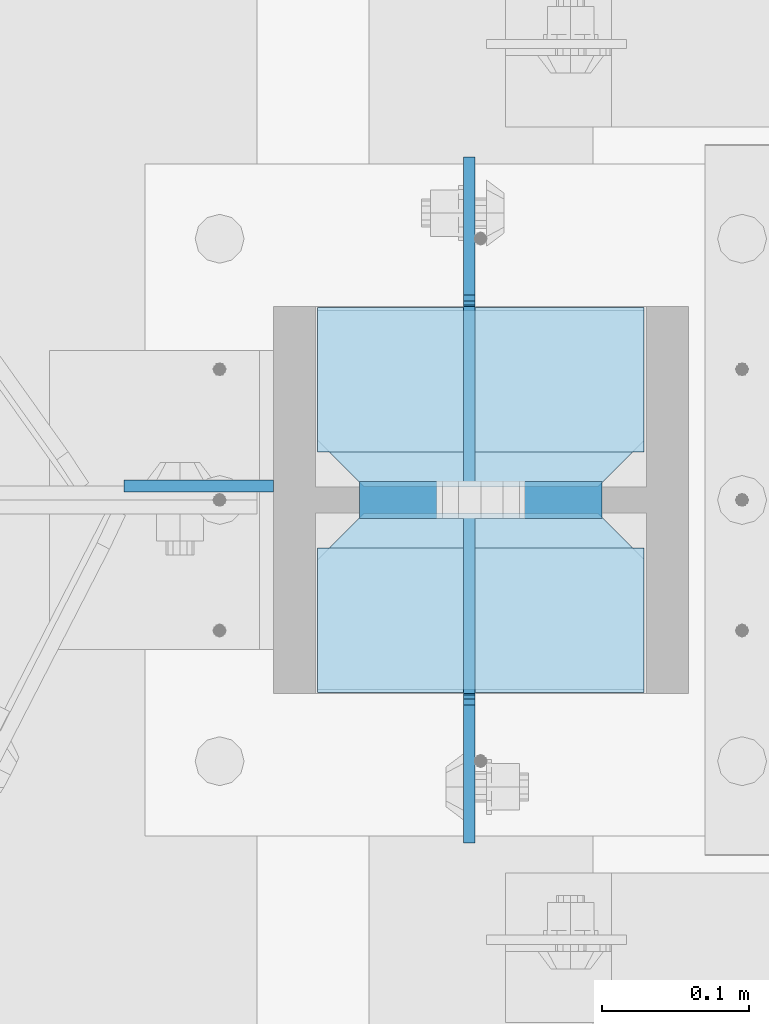
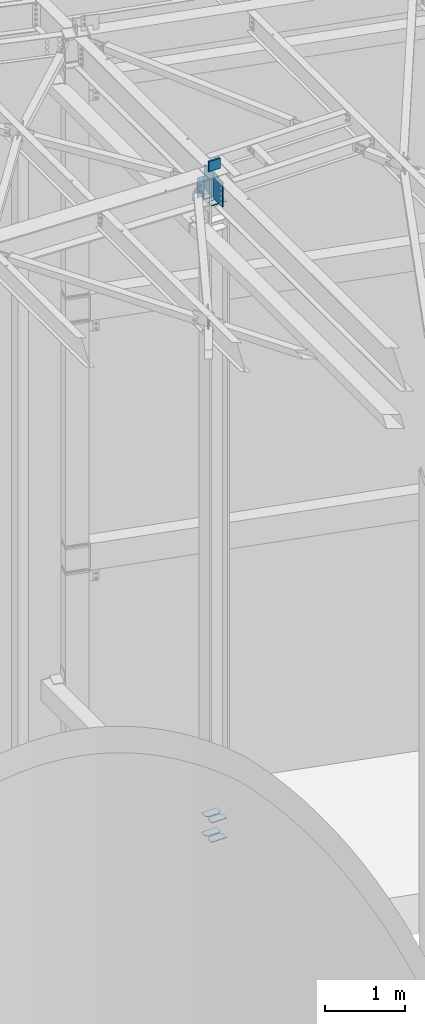
# One storey, part 1661 of 1763: 10 plates, 1 element without a shape of its own.
"""IFC2X3 building model written with IfcOpenShell, lengths in millimetres."""

import ifcopenshell
import ifcopenshell.guid

model = None  # the IFC model being written
_history = None  # IfcOwnerHistory: only IFC2X3 demands one
_inside = {}  # id of a spatial element -> (the spatial element, [elements in it])
_under = {}  # id of a project, library or spatial element -> (it, [spatial elements below it])
_declared = {}  # id of a project -> (the project, [libraries it declares])
_typed = {}  # id of a type object -> (the type object, [elements of that type])
_made_of = {}  # id of a material, layer set ... -> (it, [elements and type objects made of it])


def new_model(schema):
    """Start an empty IFC model of exactly this schema.

    Asked for "IFC4X3", IfcOpenShell would pick the latest addendum, in which some entities
    have other attributes; the version numbers below select the first issue.
    IFC2X3 requires an IfcOwnerHistory on every rooted entity: one is made here for all.
    """
    global model, _history
    if schema == "IFC4X3":
        model = ifcopenshell.file(schema_version=(4, 3, 0, 0))
    else:
        model = ifcopenshell.file(schema=schema)
    _inside.clear()
    _under.clear()
    _declared.clear()
    _typed.clear()
    _made_of.clear()
    _history = None
    if model.schema == "IFC2X3":
        org = make("IfcOrganization", Name="unknown")
        user = make(
            "IfcPersonAndOrganization",
            ThePerson=make("IfcPerson", FamilyName="unknown"),
            TheOrganization=org,
        )
        app = make(
            "IfcApplication",
            ApplicationDeveloper=org,
            Version="unknown",
            ApplicationFullName="unknown",
            ApplicationIdentifier="unknown",
        )
        _history = make(
            "IfcOwnerHistory",
            OwningUser=user,
            OwningApplication=app,
            ChangeAction="ADDED",
            CreationDate=0,
        )
    return model


def make(cls, **values):
    """One entity of the class cls with the attributes given. An attribute that is None is left unset."""
    return model.create_entity(
        cls, **{name: value for name, value in values.items() if value is not None}
    )


def rooted(cls, **values):
    """An entity with a GlobalId (a new one), such as an element, a storey or a relation."""
    return make(cls, GlobalId=ifcopenshell.guid.new(), OwnerHistory=_history, **values)


def si_unit(unit_type, name, prefix=None):
    """IfcSIUnit, for example si_unit("LENGTHUNIT", "METRE", prefix="MILLI")."""
    return make("IfcSIUnit", UnitType=unit_type, Prefix=prefix, Name=name)


def assignment(units):
    """IfcUnitAssignment: the units of a project."""
    return None if units is None else make("IfcUnitAssignment", Units=units)


def point(xyz):
    """IfcCartesianPoint."""
    return None if xyz is None else make("IfcCartesianPoint", Coordinates=xyz)


def direction(xyz):
    """IfcDirection."""
    return None if xyz is None else make("IfcDirection", DirectionRatios=xyz)


def frame(location, z_axis=None, x_axis=None):
    """IfcAxis2Placement3D, a coordinate frame: its origin and axes. An axis left out is left unset."""
    return make(
        "IfcAxis2Placement3D",
        Location=point(location),
        Axis=direction(z_axis),
        RefDirection=direction(x_axis),
    )


def origin_with_axes():
    """The frame at (0, 0, 0) with the z axis (0, 0, 1) and the x axis (1, 0, 0) written out."""
    return frame((0.0, 0.0, 0.0), z_axis=(0.0, 0.0, 1.0), x_axis=(1.0, 0.0, 0.0))


def place(relative_to, where):
    """IfcLocalPlacement: puts the frame where relative to a parent placement (None: the world)."""
    return make(
        "IfcLocalPlacement", PlacementRelTo=relative_to, RelativePlacement=where
    )


def context(
    kind, dimensions, precision=None, world=None, true_north=None, identifier=None
):
    """IfcGeometricRepresentationContext, for example the 3D "Model" context."""
    return make(
        "IfcGeometricRepresentationContext",
        ContextIdentifier=identifier,
        ContextType=kind,
        CoordinateSpaceDimension=dimensions,
        Precision=precision,
        WorldCoordinateSystem=world,
        TrueNorth=true_north,
    )


def subcontext(parent, identifier, kind, view, scale=None):
    """IfcGeometricRepresentationSubContext, for example "Body" below "Model"."""
    return make(
        "IfcGeometricRepresentationSubContext",
        ContextIdentifier=identifier,
        ContextType=kind,
        ParentContext=parent,
        TargetScale=scale,
        TargetView=view,
    )


def project(units=None, contexts=None):
    """IfcProject with its units and contexts."""
    return rooted(
        "IfcProject",
        Name="project",
        RepresentationContexts=contexts,
        UnitsInContext=assignment(units),
    )


def spatial(cls, under=None, at=None, **own):
    """A site, building, storey or space (cls), placed at a placement, below another one or the project."""
    s = rooted(cls, ObjectPlacement=at, **own)
    if under is not None:
        _under.setdefault(under.id(), (under, []))[1].append(s)
    return s


def faces_of(points, faces, orient=None, outer=None):
    """IfcFace entities. A face is a list of loops; a loop is a list of indices into points, from 0.

    orient and outer hold one flag for each loop. By default every Orientation is true, the
    first loop of a face is its IfcFaceOuterBound and the others are IfcFaceBound.
    """
    made = []
    for i, loops in enumerate(faces):
        bounds = []
        for j, loop in enumerate(loops):
            is_outer = j == 0 if outer is None else outer[i][j]
            bounds.append(
                make(
                    "IfcFaceOuterBound" if is_outer else "IfcFaceBound",
                    Bound=make("IfcPolyLoop", Polygon=[points[k] for k in loop]),
                    Orientation=True if orient is None else orient[i][j],
                )
            )
        made.append(make("IfcFace", Bounds=bounds))
    return made


def faceted_brep(points, faces, orient=None, outer=None, voids=None):
    """IfcFacetedBrep: a solid bounded by flat faces; with voids (closed shells), ...WithVoids."""
    shared = [point(p) for p in points]
    hull = make("IfcClosedShell", CfsFaces=faces_of(shared, faces, orient, outer))
    if voids is None:
        return make("IfcFacetedBrep", Outer=hull)
    return make(
        "IfcFacetedBrepWithVoids",
        Outer=hull,
        Voids=[
            make(cls, CfsFaces=faces_of(shared, fs, o, b)) for cls, fs, o, b in voids
        ],
    )


def shape(context_of_items, identifier, shape_type, items):
    """IfcShapeRepresentation: the items that make up one representation, for example the "Body"."""
    return make(
        "IfcShapeRepresentation",
        ContextOfItems=context_of_items,
        RepresentationIdentifier=identifier,
        RepresentationType=shape_type,
        Items=items,
    )


def material(Name=None, Category=None):
    """IfcMaterial."""
    return make("IfcMaterial", Name=Name, Category=Category)


def made_of(thing, what):
    """Note that an element or type object is made of a material, layer set ...; save() writes the relation."""
    if what is not None:
        _made_of.setdefault(what.id(), (what, []))[1].append(thing)
    return thing


def type_object(cls, material=None, **own):
    """A type object (cls), such as IfcWallType, which elements share."""
    return made_of(rooted(cls, **own), material)


def element(
    cls,
    number,
    at=None,
    inside=None,
    cuts=None,
    type_object=None,
    material=None,
    context=None,
    identifier="Body",
    shape_type=None,
    held_by="IfcProductDefinitionShape",
    body=None,
    shapes=None,
    **own,
):
    """One element of the class cls, such as IfcWall. Its Tag is "e" and its number.

    at: its placement. inside: the storey or other place that contains it. cuts: it is an
    opening in that element (IfcRelVoidsElement). A single representation is given by context,
    identifier, shape_type and body (its items); several are given by shapes. held_by: the class
    of the entity that holds the representations. save() writes the other relations.
    """
    e = rooted(cls, Tag="e%d" % number, ObjectPlacement=at, **own)
    if body is not None:
        shapes = [shape(context, identifier, shape_type, body)]
    if shapes is not None:
        e.Representation = make(held_by, Representations=shapes)
    if inside is not None:
        _inside.setdefault(inside.id(), (inside, []))[1].append(e)
    if cuts is not None:
        rooted(
            "IfcRelVoidsElement", RelatingBuildingElement=cuts, RelatedOpeningElement=e
        )
    if type_object is not None:
        _typed.setdefault(type_object.id(), (type_object, []))[1].append(e)
    return made_of(e, material)


def aggregate(whole, parts):
    """IfcRelAggregates: a whole, such as a stair, and the parts it consists of."""
    return rooted("IfcRelAggregates", RelatingObject=whole, RelatedObjects=parts)


def save(model, path):
    """Write the relations noted so far, then the file.

    IfcRelAggregates (storeys below a building ...), IfcRelContainedInSpatialStructure (elements
    in a storey), IfcRelDefinesByType, IfcRelAssociatesMaterial and IfcRelDeclares: one each for
    every whole, place, type object, material and project.
    """
    for whole, parts in _under.values():
        aggregate(whole, parts)
    for where, things in _inside.values():
        rooted(
            "IfcRelContainedInSpatialStructure",
            RelatedElements=things,
            RelatingStructure=where,
        )
    for kind, things in _typed.values():
        rooted("IfcRelDefinesByType", RelatedObjects=things, RelatingType=kind)
    for what, things in _made_of.values():
        rooted("IfcRelAssociatesMaterial", RelatedObjects=things, RelatingMaterial=what)
    for by, libraries in _declared.values():
        rooted("IfcRelDeclares", RelatingContext=by, RelatedDefinitions=libraries)
    model.write(path)


model = new_model("IFC2X3")

# Units and contexts
model_context = context("Model", 3, precision=1e-05, world=origin_with_axes())
body_context = subcontext(model_context, "Body", "Model", "MODEL_VIEW")
ifc_project = project(units=[si_unit("LENGTHUNIT", "METRE", prefix="MILLI"), si_unit("AREAUNIT", "SQUARE_METRE"), si_unit("VOLUMEUNIT", "CUBIC_METRE"), si_unit("MASSUNIT", "GRAM", prefix="KILO"), si_unit("TIMEUNIT", "SECOND"), si_unit("PLANEANGLEUNIT", "RADIAN"), si_unit("SOLIDANGLEUNIT", "STERADIAN"), si_unit("THERMODYNAMICTEMPERATUREUNIT", "DEGREE_CELSIUS"), si_unit("LUMINOUSINTENSITYUNIT", "LUMEN")], contexts=[model_context])

# Site, building, storey
site_placement = place(None, origin_with_axes())
site = spatial("IfcSite", under=ifc_project, at=site_placement, CompositionType="ELEMENT")
building_placement = place(site_placement, origin_with_axes())
building = spatial("IfcBuilding", under=site, at=building_placement, Name="Undefined", CompositionType="ELEMENT")
storey_placement = place(building_placement, origin_with_axes())
storey = spatial("IfcBuildingStorey", under=building, at=storey_placement, Name="Undefined", CompositionType="ELEMENT", Elevation=0.0)

# Assembly, plates
assembly_placement = place(storey_placement, origin_with_axes())
assembly = element("IfcElementAssembly", 1, at=assembly_placement, inside=storey, Name="COLUMN", AssemblyPlace="NOTDEFINED", PredefinedType="RIGID_FRAME")
ifc_material_1 = material(Name="STEEL/A36")
plate_type_1 = type_object("IfcPlateType", PredefinedType="NOTDEFINED")
plate_1_placement = place(assembly_placement, frame((-39561.1646174484, 63072.16875, 2303.4625), z_axis=(-1.0, 0.0, 0.0), x_axis=(0.0, 1.0, 0.0)))
plate_1 = element("IfcPlate", 2, at=plate_1_placement, type_object=plate_type_1, material=ifc_material_1, Name="PLATE", context=body_context, shape_type="Brep", body=[
    faceted_brep([(0.0, -4.76249999999982, 0.0), (0.0, -4.76250000000073, 222.25), (0.0, 4.76250000000073, 222.25), (0.0, 4.76249999999982, 0.0), (88.9000015258789, -4.76250000000073, 222.25), (88.9000015258789, 4.76250000000073, 222.25), (120.650001525879, -4.76250000000073, 190.5), (120.650001525879, 4.76250000000073, 190.5), (120.650001525879, -4.76249999999709, 31.75), (120.650001525879, 4.76249999999709, 31.75), (88.9000015258789, -4.76249999999709, 0.0), (88.9000015258789, 4.76249999999709, 0.0)], [[[0, 1, 2, 3]], [[1, 4, 5, 2]], [[4, 6, 7, 5]], [[6, 8, 9, 7]], [[8, 10, 11, 9]], [[10, 0, 3, 11]], [[5, 7, 9, 11, 3, 2]], [[10, 8, 6, 4, 1, 0]]]),
])
plate_2_placement = place(assembly_placement, frame((-39561.1646174484, 63210.28125, 2303.4625), z_axis=(-1.0, 0.0, 0.0), x_axis=(0.0, 1.0, 0.0)))
plate_2 = element("IfcPlate", 3, at=plate_2_placement, type_object=plate_type_1, material=ifc_material_1, Name="PLATE", context=body_context, shape_type="Brep", body=[
    faceted_brep([(0.0, -4.76250000000073, 31.75), (0.0, -4.76250000000073, 190.5), (0.0, 4.76250000000073, 190.5), (0.0, 4.76250000000073, 31.75), (31.75, -4.76250000000073, 222.25), (31.75, 4.76250000000073, 222.25), (120.650001525879, -4.76250000000073, 222.25), (120.650001525879, 4.76250000000073, 222.25), (120.650001525879, -4.76249999999709, 0.0), (120.650001525879, 4.76249999999709, 0.0), (31.75, -4.76250000000073, 0.0), (31.75, 4.76250000000073, 0.0)], [[[0, 1, 2, 3]], [[1, 4, 5, 2]], [[4, 6, 7, 5]], [[6, 8, 9, 7]], [[8, 10, 11, 9]], [[10, 0, 3, 11]], [[5, 7, 9, 11, 3, 2]], [[10, 8, 6, 4, 1, 0]]]),
])
plate_3_placement = place(assembly_placement, frame((-39561.1646174484, 63072.16875, 2598.7375), z_axis=(-1.0, 0.0, 0.0), x_axis=(0.0, 1.0, 0.0)))
plate_3 = element("IfcPlate", 4, at=plate_3_placement, type_object=plate_type_1, material=ifc_material_1, Name="PLATE", context=body_context, shape_type="Brep", body=[
    faceted_brep([(0.0, -4.76249999999982, 0.0), (0.0, -4.76250000000073, 222.25), (0.0, 4.76250000000073, 222.25), (0.0, 4.76249999999982, 0.0), (88.9000015258789, -4.76250000000073, 222.25), (88.9000015258789, 4.76250000000073, 222.25), (120.650001525879, -4.76250000000073, 190.5), (120.650001525879, 4.76250000000073, 190.5), (120.650001525879, -4.76249999999709, 31.75), (120.650001525879, 4.76249999999709, 31.75), (88.9000015258789, -4.76249999999709, 0.0), (88.9000015258789, 4.76249999999709, 0.0)], [[[0, 1, 2, 3]], [[1, 4, 5, 2]], [[4, 6, 7, 5]], [[6, 8, 9, 7]], [[8, 10, 11, 9]], [[10, 0, 3, 11]], [[5, 7, 9, 11, 3, 2]], [[10, 8, 6, 4, 1, 0]]]),
])
plate_4_placement = place(assembly_placement, frame((-39561.1646174484, 63210.28125, 2598.7375), z_axis=(-1.0, 0.0, 0.0), x_axis=(0.0, 1.0, 0.0)))
plate_4 = element("IfcPlate", 5, at=plate_4_placement, type_object=plate_type_1, material=ifc_material_1, Name="PLATE", context=body_context, shape_type="Brep", body=[
    faceted_brep([(0.0, -4.76250000000073, 31.75), (0.0, -4.76250000000073, 190.5), (0.0, 4.76250000000073, 190.5), (0.0, 4.76250000000073, 31.75), (31.75, -4.76250000000073, 222.25), (31.75, 4.76250000000073, 222.25), (120.650001525879, -4.76250000000073, 222.25), (120.650001525879, 4.76250000000073, 222.25), (120.650001525879, -4.76249999999709, 0.0), (120.650001525879, 4.76249999999709, 0.0), (31.75, -4.76250000000073, 0.0), (31.75, 4.76250000000073, 0.0)], [[[0, 1, 2, 3]], [[1, 4, 5, 2]], [[4, 6, 7, 5]], [[6, 8, 9, 7]], [[8, 10, 11, 9]], [[10, 0, 3, 11]], [[5, 7, 9, 11, 3, 2]], [[10, 8, 6, 4, 1, 0]]]),
])
plate_type_2 = type_object("IfcPlateType", PredefinedType="NOTDEFINED")
plate_5_placement = place(assembly_placement, frame((-39813.5771174488, 63211.0752499998, 12407.8212128079), z_axis=(-1.0, 0.0, 0.0), x_axis=(0.0, 0.0, -1.0)))
plate_5 = element("IfcPlate", 6, at=plate_5_placement, type_object=plate_type_2, material=ifc_material_1, Name="PLATE", context=body_context, shape_type="Brep", body=[
    faceted_brep([(0.0, -3.96900000000096, 0.0), (-1.18234311230481e-11, -3.96900000000096, 101.599998474121), (-1.18234311230481e-11, 3.96900000000096, 101.599998474121), (0.0, 3.96900000000096, 0.0), (304.799987792969, -3.96900000000096, 101.599998474121), (304.799987792969, 3.96900000000096, 101.599998474121), (304.799987792969, -3.96900000000096, -3.63797880709171e-11), (304.799987792969, 3.96900000000096, -3.63797880709171e-11)], [[[0, 1, 2, 3]], [[1, 4, 5, 2]], [[4, 6, 7, 5]], [[6, 0, 3, 7]], [[5, 7, 3, 2]], [[6, 4, 1, 0]]]),
])
ifc_material_2 = material(Name="STEEL/A572-50")
plate_type_3 = type_object("IfcPlateType", PredefinedType="NOTDEFINED")
plate_6_placement = place(assembly_placement, frame((-39589.7396159201, 63201.5499999723, 12611.0999938965), z_axis=(0.0, 0.0, -1.0), x_axis=(-1.0, 0.0, 0.0)))
plate_6 = element("IfcPlate", 7, at=plate_6_placement, type_object=plate_type_3, material=ifc_material_2, Name="PLATE", context=body_context, shape_type="Brep", body=[
    faceted_brep([(0.0, 12.7, 152.399990844726), (-1.45519152283669e-11, 7.27595761418343e-12, 165.099990844727), (165.099990844727, 0.0, 165.099990844727), (165.099990844727, 12.7, 152.399990844726), (0.0, -12.7, 152.399990844726), (165.099990844727, -12.7, 152.399990844726), (0.0, 12.6999999999971, -1.81898940354586e-12), (0.0, -12.6999999999971, -1.81898940354586e-12), (165.099990844727, -12.7, 0.0), (165.099990844727, 12.7, 0.0)], [[[0, 1, 2, 3]], [[1, 4, 5, 2]], [[6, 7, 4, 1, 0]], [[5, 8, 9, 3, 2]], [[8, 7, 6, 9]], [[9, 6, 0, 3]], [[7, 8, 5, 4]]]),
])
plate_type_4 = type_object("IfcPlateType", PredefinedType="NOTDEFINED")
plate_7_placement = place(assembly_placement, frame((-39783.4146174484, 63070.58125, 12020.5500053465), z_axis=(1.0, 0.0, 0.0), x_axis=(0.0, 1.0, 0.0)))
plate_7 = element("IfcPlate", 8, at=plate_7_placement, type_object=plate_type_4, material=ifc_material_1, Name="PLATE", context=body_context, shape_type="Brep", body=[
    faceted_brep([(0.0, -6.34999999999491, 1.45519152283669e-11), (0.0, -6.35000000000036, 222.25), (0.0, 6.35000000000036, 222.25), (0.0, 6.34999999999491, -2.91038304567337e-11), (98.4250030517578, -6.35000000000036, 222.25), (98.4250030517578, 6.35000000000036, 222.25), (98.4250030517578, -6.35000000000036, 0.0), (98.4250030517578, 6.35000000000036, 0.0)], [[[0, 1, 2, 3]], [[1, 4, 5, 2]], [[4, 6, 7, 5]], [[6, 0, 3, 7]], [[5, 7, 3, 2]], [[6, 4, 1, 0]]]),
])
plate_8_placement = place(assembly_placement, frame((-39561.1646174484, 63332.51875, 12020.5500053465), z_axis=(-1.0, 0.0, 0.0), x_axis=(0.0, -1.0, 0.0)))
plate_8 = element("IfcPlate", 9, at=plate_8_placement, type_object=plate_type_4, material=ifc_material_1, Name="PLATE", context=body_context, shape_type="Brep", body=[
    faceted_brep([(0.0, -6.34999999999491, 1.45519152283669e-11), (0.0, -6.35000000000036, 222.25), (0.0, 6.35000000000036, 222.25), (0.0, 6.34999999999491, -2.91038304567337e-11), (98.4250030517578, -6.35000000000036, 222.25), (98.4250030517578, 6.35000000000036, 222.25), (98.4250030517578, -6.35000000000036, 0.0), (98.4250030517578, 6.35000000000036, 0.0)], [[[0, 1, 2, 3]], [[1, 4, 5, 2]], [[4, 6, 7, 5]], [[6, 0, 3, 7]], [[5, 7, 3, 2]], [[6, 4, 1, 0]]]),
])
plate_type_5 = type_object("IfcPlateType", PredefinedType="NOTDEFINED")
plate_9_placement = place(assembly_placement, frame((-39680.2273674484, 63192.81875, 12433.299999243), z_axis=(0.0, -1.0, 0.0), x_axis=(0.0, 0.0, -1.0)))
plate_9 = element("IfcPlate", 10, at=plate_9_placement, type_object=plate_type_5, material=ifc_material_1, Name="PLATE", context=body_context, shape_type="Brep", body=[
    faceted_brep([(12.6999979078773, -3.96899999999732, 123.031250000015), (12.6999979078773, 3.96899999999732, 123.031250000015), (0.0, 3.96899999999732, 123.031250000015), (0.0, -3.96899999999732, 123.031250000015), (17.5600774259237, -3.96899999999732, 123.997979922606), (17.5600774259237, 3.96899999999732, 123.997979922606), (21.6802538940774, -3.96899999999732, 126.75099382308), (21.6802538940774, 3.96899999999732, 126.75099382308), (24.4332677945549, -3.96899999999732, 130.871170291233), (24.4332677945549, 3.96899999999732, 130.871170291233), (25.3999977171425, -3.96899999999732, 135.73124980928), (25.3999977171425, 3.96899999999732, 135.73124980928), (25.3999977171425, -3.96899999999732, 224.63125610353), (25.3999977171425, 3.96899999999732, 224.631256103516), (406.399993896484, -3.96899999999732, 0.0), (0.0, -3.96900000000096, 0.0), (0.0, 3.96900000000096, 0.0), (406.399993896484, 3.96899999999732, 0.0), (406.399993896484, -3.96899999999732, 224.631256103516), (406.399993896484, 3.96899999999732, 224.631256103516)], [[[0, 1, 2, 3]], [[4, 5, 1, 0]], [[6, 7, 5, 4]], [[8, 9, 7, 6]], [[10, 11, 9, 8]], [[12, 13, 11, 10]], [[14, 15, 16, 17]], [[18, 14, 17, 19]], [[8, 6, 4, 0, 3, 15, 14, 18, 12, 10]], [[16, 15, 3, 2]], [[19, 17, 16, 2, 1, 5, 7, 9, 11, 13]], [[18, 19, 13, 12]]]),
])
plate_10_placement = place(assembly_placement, frame((-39680.2273674484, 63210.28125, 12433.299999243), z_axis=(0.0, 1.0, 0.0), x_axis=(0.0, 0.0, -1.0)))
plate_10 = element("IfcPlate", 11, at=plate_10_placement, type_object=plate_type_5, material=ifc_material_1, Name="PLATE", context=body_context, shape_type="Brep", body=[
    faceted_brep([(12.6999979078773, -3.96899999999732, 123.031250000015), (12.6999979078773, 3.96899999999732, 123.031250000015), (0.0, 3.96899999999732, 123.031250000015), (0.0, -3.96899999999732, 123.031250000015), (17.5600774259237, -3.96899999999732, 123.997979922606), (17.5600774259237, 3.96899999999732, 123.997979922606), (21.6802538940774, -3.96899999999732, 126.75099382308), (21.6802538940774, 3.96899999999732, 126.75099382308), (24.4332677945549, -3.96899999999732, 130.871170291233), (24.4332677945549, 3.96899999999732, 130.871170291233), (25.3999977171425, -3.96899999999732, 135.73124980928), (25.3999977171425, 3.96899999999732, 135.73124980928), (25.3999977171425, -3.96899999999732, 224.63125610353), (25.3999977171425, 3.96899999999732, 224.631256103516), (406.399993896484, -3.96899999999732, 0.0), (0.0, -3.96900000000096, 0.0), (0.0, 3.96900000000096, 0.0), (406.399993896484, 3.96899999999732, 0.0), (406.399993896484, -3.96899999999732, 224.631256103516), (406.399993896484, 3.96899999999732, 224.631256103516)], [[[0, 1, 2, 3]], [[4, 5, 1, 0]], [[6, 7, 5, 4]], [[8, 9, 7, 6]], [[10, 11, 9, 8]], [[12, 13, 11, 10]], [[14, 15, 16, 17]], [[18, 14, 17, 19]], [[8, 6, 4, 0, 3, 15, 14, 18, 12, 10]], [[16, 15, 3, 2]], [[19, 17, 16, 2, 1, 5, 7, 9, 11, 13]], [[18, 19, 13, 12]]]),
])
aggregate(assembly, [plate_1, plate_2, plate_3, plate_4, plate_6, plate_7, plate_9, plate_8, plate_10, plate_5])

save(model, "model.ifc")
